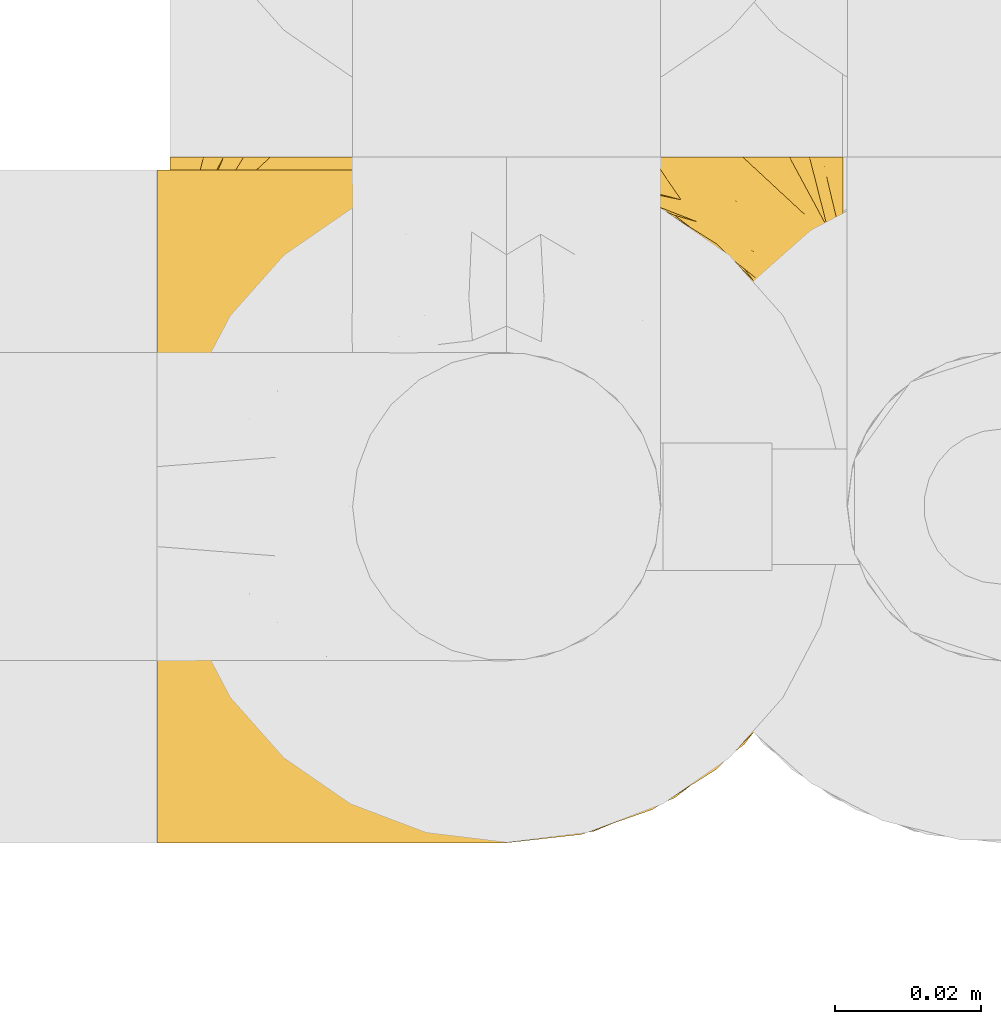
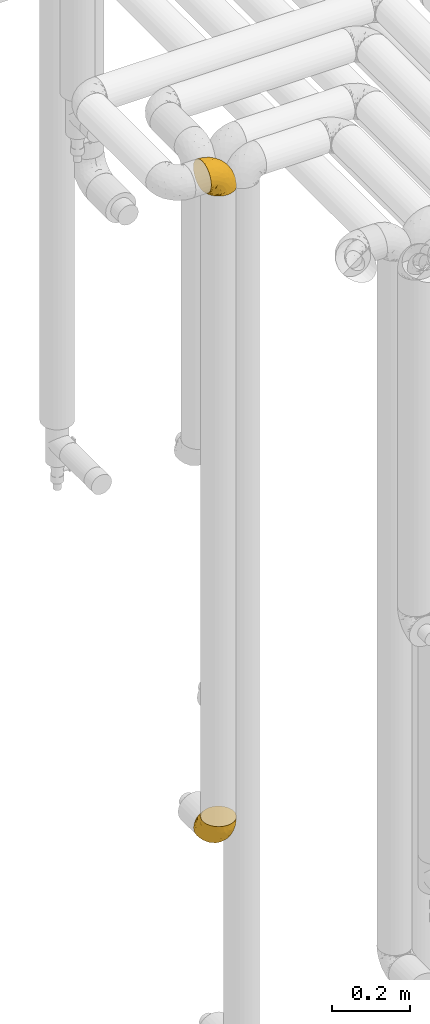
# One storey, part 250 of 827: 2 coverings.
"""IFC2X3 building model written with IfcOpenShell, lengths in millimetres."""

from ifc_helpers import new_model, entity, si_unit, converted_unit, derived_unit, direction, frame, origin, place, context, subcontext, project, spatial, faceted_brep, element, save


model = new_model("IFC2X3")

# Units and contexts
model_context = context("Model", 3, precision=0.01, world=origin(), true_north=direction((6.12303176911189e-17, 1.0)))
body_context = subcontext(model_context, "Body", "Model", "MODEL_VIEW")
ifc_project = project(units=[si_unit("LENGTHUNIT", "METRE", prefix="MILLI"), si_unit("AREAUNIT", "SQUARE_METRE"), si_unit("VOLUMEUNIT", "CUBIC_METRE"), converted_unit("PLANEANGLEUNIT", "DEGREE", entity("IfcRatioMeasure", 0.0174532925199433), si_unit("PLANEANGLEUNIT", "RADIAN"), dimensions=[0, 0, 0, 0, 0, 0, 0]), si_unit("MASSUNIT", "GRAM", prefix="KILO"), derived_unit("MASSDENSITYUNIT", [(si_unit("MASSUNIT", "GRAM", prefix="KILO"), 1), (si_unit("LENGTHUNIT", "METRE"), -3)]), derived_unit("MOMENTOFINERTIAUNIT", [(si_unit("LENGTHUNIT", "METRE"), 4)]), si_unit("TIMEUNIT", "SECOND"), si_unit("FREQUENCYUNIT", "HERTZ"), si_unit("THERMODYNAMICTEMPERATUREUNIT", "DEGREE_CELSIUS"), derived_unit("THERMALTRANSMITTANCEUNIT", [(si_unit("MASSUNIT", "GRAM", prefix="KILO"), 1), (si_unit("THERMODYNAMICTEMPERATUREUNIT", "KELVIN"), -1), (si_unit("TIMEUNIT", "SECOND"), -3)]), derived_unit("VOLUMETRICFLOWRATEUNIT", [(si_unit("LENGTHUNIT", "METRE"), 3), (si_unit("TIMEUNIT", "SECOND"), -1)]), derived_unit("MASSFLOWRATEUNIT", [(si_unit("MASSUNIT", "GRAM", prefix="KILO"), 1), (si_unit("TIMEUNIT", "SECOND"), -1)]), derived_unit("ROTATIONALFREQUENCYUNIT", [(si_unit("TIMEUNIT", "SECOND"), -1)]), si_unit("ELECTRICCURRENTUNIT", "AMPERE"), si_unit("ELECTRICVOLTAGEUNIT", "VOLT"), si_unit("POWERUNIT", "WATT"), si_unit("FORCEUNIT", "NEWTON", prefix="KILO"), si_unit("ILLUMINANCEUNIT", "LUX"), si_unit("LUMINOUSFLUXUNIT", "LUMEN"), si_unit("LUMINOUSINTENSITYUNIT", "CANDELA"), derived_unit("USERDEFINED", [(si_unit("MASSUNIT", "GRAM", prefix="KILO"), -1), (si_unit("LENGTHUNIT", "METRE"), -2), (si_unit("TIMEUNIT", "SECOND"), 3), (si_unit("LUMINOUSFLUXUNIT", "LUMEN"), 1)]), derived_unit("LINEARVELOCITYUNIT", [(si_unit("LENGTHUNIT", "METRE"), 1), (si_unit("TIMEUNIT", "SECOND"), -1)]), si_unit("PRESSUREUNIT", "PASCAL"), derived_unit("USERDEFINED", [(si_unit("LENGTHUNIT", "METRE"), -2), (si_unit("MASSUNIT", "GRAM", prefix="KILO"), 1), (si_unit("TIMEUNIT", "SECOND"), -2)]), derived_unit("LINEARFORCEUNIT", [(si_unit("MASSUNIT", "GRAM", prefix="KILO"), 1), (si_unit("LENGTHUNIT", "METRE"), 1), (si_unit("TIMEUNIT", "SECOND"), -2), (si_unit("LENGTHUNIT", "METRE"), -1)]), derived_unit("PLANARFORCEUNIT", [(si_unit("MASSUNIT", "GRAM", prefix="KILO"), 1), (si_unit("LENGTHUNIT", "METRE"), 1), (si_unit("TIMEUNIT", "SECOND"), -2), (si_unit("LENGTHUNIT", "METRE"), -2)])], contexts=[model_context])

# Site, building, storey
site_placement = place(None, origin())
site = spatial("IfcSite", under=ifc_project, at=site_placement, CompositionType="ELEMENT")
building_placement = place(site_placement, origin())
building = spatial("IfcBuilding", under=site, at=building_placement, CompositionType="ELEMENT")
storey_placement = place(building_placement, frame((0.0, 0.0, 28200.0)))
storey = spatial("IfcBuildingStorey", under=building, at=storey_placement, Name="08", CompositionType="ELEMENT", Elevation=28200.0)

# Coverings
covering_1_placement = place(storey_placement, frame((30513.93, 15693.41, 3150.4)))
element("IfcCovering", 1, at=covering_1_placement, inside=storey, Name=":ADSK_", ObjectType=":ADSK_", PredefinedType="INSULATION", context=body_context, shape_type="Brep", body=[
    faceted_brep([(78.41, 83.91, 1.6), (85.72, 76.59, 1.6), (91.22, 67.83, 1.6), (94.64, 58.07, 1.6), (95.8, 47.8, 1.6), (94.64, 37.51, 1.6), (91.22, 27.74, 1.6), (85.71, 18.98, 1.6), (78.39, 11.67, 1.6), (69.63, 6.17, 1.6), (59.87, 2.75, 1.6), (49.6, 1.6, 1.6), (45.45, 2.06, 1.6), (42.38, 2.41, 1.6), (39.31, 2.75, 1.6), (34.43, 4.46, 1.6), (29.54, 6.17, 1.6), (25.16, 8.93, 1.6), (20.78, 11.68, 1.6), (17.13, 15.34, 1.6), (13.47, 19.0, 1.6), (7.97, 27.76, 1.6), (6.26, 32.64, 1.6), (4.55, 37.52, 1.6), (3.4, 47.8, 1.6), (4.55, 58.08, 1.6), (6.26, 62.96, 1.6), (7.97, 67.85, 1.6), (13.48, 76.61, 1.6), (17.14, 80.26, 1.6), (20.8, 83.92, 1.6), (25.18, 86.67, 1.6), (29.56, 89.42, 1.6), (34.44, 91.13, 1.6), (39.32, 92.84, 1.6), (42.39, 93.18, 1.6), (45.45, 93.53, 1.6), (49.6, 94.0, 1.6), (59.88, 92.84, 1.6), (69.65, 89.42, 1.6), (1.6, 47.8, 3.4), (1.6, 35.84, 4.97), (1.6, 24.7, 9.58), (1.6, 19.91, 13.26), (1.6, 15.13, 16.93), (1.6, 11.46, 21.71), (1.6, 7.78, 26.5), (1.6, 5.48, 32.07), (1.6, 3.17, 37.64), (1.6, 2.69, 41.25), (1.6, 2.42, 43.34), (1.6, 2.14, 45.42), (1.6, 1.6, 49.6), (1.6, 3.17, 61.55), (1.6, 7.78, 72.7), (1.6, 15.13, 82.26), (1.6, 24.7, 89.61), (1.6, 35.84, 94.22), (1.6, 47.8, 95.8), (1.6, 59.75, 94.22), (1.6, 70.9, 89.61), (1.6, 80.46, 82.26), (1.6, 87.81, 72.7), (1.6, 92.42, 61.55), (1.6, 94.0, 49.6), (1.6, 93.45, 45.42), (1.6, 92.9, 41.25), (1.6, 92.42, 37.64), (1.6, 90.11, 32.07), (1.6, 87.81, 26.5), (1.6, 84.13, 21.71), (1.6, 80.46, 16.93), (1.6, 75.68, 13.26), (1.6, 70.9, 9.58), (1.6, 59.75, 4.97), (36.81, 71.98, 81.55), (23.28, 63.6, 90.4), (45.8, 59.72, 83.0), (30.7, 47.8, 91.18), (21.2, 55.16, 93.13), (12.96, 47.8, 94.0), (66.19, 63.76, 66.19), (54.51, 72.22, 70.92), (17.98, 74.18, 85.95), (36.69, 92.52, 49.74), (35.54, 94.0, 35.54), (31.64, 94.0, 38.14), (27.75, 94.0, 40.74), (23.86, 94.0, 43.34), (19.96, 94.0, 45.94), (22.8, 82.14, 77.59), (42.67, 80.34, 71.17), (33.21, 87.52, 65.81), (59.45, 79.59, 59.03), (71.5, 78.25, 45.85), (62.66, 85.01, 45.79), (54.5, 90.25, 41.42), (47.57, 93.2, 34.51), (48.81, 87.23, 56.04), (74.98, 85.55, 15.15), (18.7, 93.0, 56.51), (15.75, 89.31, 68.39), (91.17, 61.31, 23.33), (85.28, 56.86, 42.86), (82.58, 68.34, 39.42), (75.78, 65.71, 53.58), (74.98, 56.99, 59.17), (67.27, 72.15, 59.06), (87.38, 70.34, 22.63), (82.04, 78.36, 20.55), (94.0, 47.8, 12.96), (77.8, 47.8, 56.96), (67.38, 47.8, 67.38), (56.2, 93.06, 18.72), (48.85, 94.0, 5.33), (48.11, 94.0, 9.07), (47.57, 94.0, 11.79), (47.03, 94.0, 14.51), (46.48, 94.0, 17.24), (45.94, 94.0, 19.96), (65.78, 89.88, 21.03), (17.24, 94.0, 46.48), (14.51, 94.0, 47.03), (11.79, 94.0, 47.57), (9.07, 94.0, 48.11), (7.2, 94.0, 48.48), (5.33, 94.0, 48.85), (91.18, 47.8, 30.7), (43.34, 94.0, 23.86), (40.74, 94.0, 27.75), (38.14, 94.0, 31.64), (72.73, 83.7, 31.26), (56.96, 47.8, 77.8), (62.23, 55.9, 72.75), (84.49, 47.8, 43.83), (43.83, 47.8, 84.49), (12.05, 81.75, 14.58), (18.95, 86.43, 16.17), (13.02, 79.8, 10.82), (8.34, 69.84, 4.64), (14.63, 79.5, 7.71), (11.09, 88.08, 25.13), (13.66, 91.6, 32.66), (20.08, 92.93, 34.94), (9.61, 92.43, 36.76), (9.48, 93.24, 40.48), (16.1, 93.36, 39.25), (3.42, 57.25, 3.69), (26.63, 89.41, 13.99), (33.72, 92.89, 21.85), (34.77, 92.66, 17.93), (6.75, 79.58, 15.11), (13.31, 86.51, 21.14), (21.11, 86.29, 12.7), (19.94, 83.91, 7.21), (8.67, 90.94, 32.27), (26.11, 91.94, 25.68), (29.3, 91.98, 22.18), (6.32, 82.79, 18.79), (39.92, 93.16, 10.12), (27.05, 88.76, 9.47), (6.04, 73.94, 10.45), (34.4, 91.89, 11.29), (2.87, 47.8, 2.87), (20.92, 92.22, 31.16), (27.43, 88.56, 6.31), (7.54, 87.72, 25.62), (18.45, 88.33, 21.18), (23.88, 92.18, 28.81), (7.77, 71.78, 7.45), (13.3, 9.09, 21.14), (11.09, 7.51, 25.13), (6.33, 12.8, 18.79), (9.07, 1.6, 48.11), (5.33, 1.6, 48.85), (14.51, 1.6, 47.03), (11.79, 1.6, 47.57), (3.42, 38.35, 3.69), (7.76, 23.84, 7.44), (47.03, 1.6, 14.51), (47.57, 1.6, 11.79), (48.85, 1.6, 5.33), (48.11, 1.6, 9.07), (14.62, 16.1, 7.71), (27.03, 6.84, 9.47), (20.08, 2.66, 34.94), (20.92, 3.37, 31.16), (27.75, 1.6, 40.74), (31.64, 1.6, 38.14), (9.61, 3.16, 36.76), (9.48, 2.35, 40.48), (8.33, 25.77, 4.63), (6.74, 16.02, 15.11), (12.04, 13.85, 14.58), (23.86, 1.6, 43.34), (19.96, 1.6, 45.94), (16.1, 2.23, 39.25), (19.93, 11.69, 7.21), (21.1, 9.31, 12.69), (39.92, 2.43, 10.14), (33.68, 2.71, 21.81), (29.28, 3.61, 22.19), (26.62, 6.18, 14.0), (26.08, 3.66, 25.69), (18.93, 9.17, 16.17), (27.87, 6.77, 6.66), (34.75, 2.93, 17.92), (6.04, 21.66, 10.45), (38.14, 1.6, 31.64), (12.79, 16.09, 10.64), (34.41, 3.7, 11.31), (45.94, 1.6, 19.96), (43.34, 1.6, 23.86), (40.74, 1.6, 27.75), (13.66, 3.99, 32.66), (17.24, 1.6, 46.48), (8.67, 4.65, 32.27), (35.54, 1.6, 35.54), (23.83, 3.43, 28.77), (18.43, 7.27, 21.17), (6.03, 9.46, 23.36), (46.48, 1.6, 17.24), (34.52, 2.4, 47.58), (21.2, 40.43, 93.13), (23.82, 13.57, 77.44), (41.32, 11.3, 66.78), (47.62, 18.65, 71.68), (52.66, 27.26, 74.96), (36.81, 23.61, 81.55), (49.75, 3.07, 36.7), (19.07, 2.69, 56.9), (45.8, 35.87, 83.0), (23.28, 31.99, 90.4), (21.35, 6.71, 67.83), (17.98, 21.41, 85.95), (82.57, 27.24, 39.41), (91.17, 34.26, 23.33), (85.27, 38.73, 42.87), (73.89, 26.97, 53.92), (66.19, 31.83, 66.19), (62.43, 23.4, 64.12), (63.53, 6.91, 33.13), (58.45, 3.4, 23.1), (67.16, 5.84, 16.98), (62.22, 39.69, 72.75), (81.54, 17.6, 23.77), (74.8, 10.38, 18.41), (75.83, 20.6, 43.7), (41.45, 5.36, 54.53), (76.72, 35.73, 55.72), (88.2, 24.84, 17.73), (71.6, 13.87, 38.98), (56.23, 9.06, 50.28), (59.44, 15.99, 59.02)], [[[0, 1, 2, 3, 4, 5, 6, 7, 8, 9, 10, 11, 12, 13, 14, 15, 16, 17, 18, 19, 20, 21, 22, 23, 24, 25, 26, 27, 28, 29, 30, 31, 32, 33, 34, 35, 36, 37, 38, 39]], [[40, 41, 42, 43, 44, 45, 46, 47, 48, 49, 50, 51, 52, 53, 54, 55, 56, 57, 58, 59, 60, 61, 62, 63, 64, 65, 66, 67, 68, 69, 70, 71, 72, 73, 74]], [[75, 76, 77]], [[78, 79, 80]], [[77, 81, 82]], [[76, 75, 83]], [[84, 85, 86, 87, 88, 89]], [[90, 91, 92]], [[76, 60, 59]], [[93, 94, 95]], [[90, 62, 61]], [[83, 61, 60]], [[96, 97, 84]], [[98, 93, 95]], [[0, 39, 99]], [[100, 84, 89]], [[62, 101, 63]], [[2, 102, 3]], [[92, 84, 100]], [[103, 102, 104]], [[103, 105, 106]], [[93, 107, 94]], [[1, 108, 2]], [[92, 101, 90]], [[108, 1, 109]], [[102, 110, 3]], [[93, 82, 107]], [[102, 108, 104]], [[111, 106, 112]], [[109, 0, 99]], [[113, 37, 114, 115, 116, 117, 118, 119]], [[120, 38, 113]], [[100, 89, 121, 122, 123, 124, 125, 126, 64]], [[127, 102, 103]], [[97, 119, 128, 129, 130, 85]], [[99, 120, 131]], [[132, 133, 77]], [[59, 80, 79]], [[1, 0, 109]], [[98, 84, 92]], [[94, 109, 131]], [[120, 39, 38]], [[93, 91, 82]], [[104, 94, 105]], [[97, 113, 119]], [[95, 120, 96]], [[83, 90, 61]], [[91, 93, 98]], [[64, 63, 100]], [[100, 63, 101]], [[77, 76, 79]], [[133, 106, 81]], [[84, 97, 85]], [[113, 96, 120]], [[113, 97, 96]], [[37, 113, 38]], [[110, 102, 127]], [[110, 4, 3]], [[103, 111, 134, 127]], [[90, 75, 91]], [[82, 81, 107]], [[91, 75, 82]], [[77, 82, 75]], [[76, 83, 60]], [[90, 83, 75]], [[105, 107, 81]], [[94, 131, 95]], [[105, 94, 107]], [[109, 94, 104]], [[120, 95, 131]], [[98, 95, 96]], [[84, 98, 96]], [[98, 92, 91]], [[106, 105, 81]], [[103, 104, 105]], [[112, 106, 133]], [[103, 106, 111]], [[112, 133, 132]], [[81, 77, 133]], [[77, 78, 135, 132]], [[120, 99, 39]], [[109, 99, 131]], [[59, 58, 80]], [[59, 79, 76]], [[90, 101, 62]], [[100, 101, 92]], [[2, 108, 102]], [[109, 104, 108]], [[78, 77, 79]], [[136, 137, 138]], [[27, 139, 140]], [[141, 142, 143]], [[144, 145, 121]], [[146, 89, 88]], [[147, 139, 25]], [[148, 149, 150]], [[136, 151, 152]], [[147, 40, 74]], [[24, 147, 25]], [[140, 153, 154]], [[33, 116, 34]], [[73, 72, 151]], [[114, 37, 36, 35, 34, 116, 115]], [[146, 155, 144]], [[156, 85, 130]], [[157, 149, 148]], [[151, 158, 152]], [[117, 33, 159]], [[29, 154, 160]], [[161, 74, 73]], [[162, 128, 119]], [[66, 65, 64, 126, 125, 124, 123, 122, 67]], [[163, 147, 24]], [[27, 140, 28]], [[149, 129, 150]], [[139, 27, 26, 25]], [[68, 144, 69]], [[129, 128, 150]], [[164, 87, 86]], [[130, 129, 149]], [[122, 145, 67]], [[154, 153, 148]], [[162, 119, 159]], [[165, 30, 160]], [[150, 160, 148]], [[128, 162, 150]], [[30, 165, 31]], [[145, 144, 68]], [[89, 146, 144]], [[87, 164, 143]], [[166, 155, 142]], [[88, 87, 143]], [[162, 160, 150]], [[160, 30, 29]], [[154, 29, 28]], [[140, 154, 28]], [[160, 154, 148]], [[140, 137, 153]], [[157, 148, 153]], [[156, 130, 157]], [[153, 137, 157]], [[157, 137, 156]], [[167, 137, 136]], [[168, 85, 156]], [[152, 168, 167]], [[167, 168, 156]], [[164, 152, 141]], [[71, 158, 72]], [[152, 167, 136]], [[88, 142, 146]], [[144, 155, 69]], [[146, 142, 155]], [[70, 166, 71]], [[142, 141, 166]], [[70, 69, 155]], [[141, 158, 71]], [[161, 73, 151]], [[138, 137, 140]], [[161, 136, 169]], [[136, 161, 151]], [[74, 161, 169]], [[152, 158, 141]], [[151, 72, 158]], [[168, 152, 164]], [[137, 167, 156]], [[164, 86, 168]], [[85, 168, 86]], [[116, 33, 117]], [[130, 149, 157]], [[67, 145, 68]], [[121, 89, 144]], [[145, 122, 121]], [[40, 147, 163]], [[169, 147, 74]], [[159, 33, 32]], [[162, 159, 32]], [[159, 119, 118, 117]], [[139, 147, 169]], [[139, 169, 138]], [[162, 32, 31]], [[141, 143, 164]], [[88, 143, 142]], [[71, 166, 141]], [[155, 166, 70]], [[139, 138, 140]], [[169, 136, 138]], [[160, 162, 165]], [[162, 31, 165]], [[170, 171, 172]], [[173, 174, 52, 51, 50, 49, 48, 175, 176]], [[177, 178, 41]], [[179, 15, 180]], [[12, 11, 181, 182, 180, 14, 13]], [[183, 21, 20]], [[19, 18, 184]], [[185, 186, 187]], [[186, 188, 187]], [[43, 172, 44]], [[189, 190, 47]], [[23, 22, 21, 191]], [[170, 192, 193]], [[40, 163, 177]], [[194, 195, 196]], [[24, 23, 177]], [[197, 198, 183]], [[199, 15, 179]], [[47, 46, 189]], [[200, 201, 202]], [[201, 203, 204]], [[205, 206, 184]], [[207, 41, 178]], [[16, 15, 199]], [[14, 180, 15]], [[202, 201, 198]], [[208, 201, 200]], [[163, 24, 177]], [[48, 47, 190]], [[196, 195, 189]], [[197, 184, 202]], [[204, 193, 209]], [[210, 211, 212]], [[206, 212, 213]], [[205, 17, 210]], [[184, 206, 202]], [[210, 212, 206]], [[185, 194, 214]], [[189, 215, 190]], [[216, 45, 214]], [[186, 171, 170]], [[189, 216, 196]], [[197, 20, 19]], [[194, 185, 187]], [[197, 183, 20]], [[184, 197, 19]], [[197, 202, 198]], [[206, 200, 202]], [[204, 183, 198]], [[201, 208, 203]], [[203, 208, 217]], [[204, 198, 201]], [[217, 188, 218]], [[193, 219, 170]], [[171, 186, 185]], [[170, 218, 186]], [[170, 219, 218]], [[42, 207, 192]], [[171, 220, 172]], [[216, 189, 46]], [[214, 194, 196]], [[44, 220, 45]], [[214, 196, 216]], [[216, 46, 45]], [[214, 45, 220]], [[192, 43, 42]], [[204, 203, 219]], [[207, 193, 192]], [[209, 193, 178]], [[41, 207, 42]], [[193, 207, 178]], [[43, 192, 172]], [[170, 172, 192]], [[204, 219, 193]], [[219, 203, 218]], [[217, 218, 203]], [[188, 186, 218]], [[206, 213, 200]], [[208, 200, 213]], [[199, 210, 16]], [[215, 189, 195]], [[215, 175, 190]], [[175, 48, 190]], [[199, 179, 221, 211]], [[210, 199, 211]], [[23, 191, 177]], [[40, 177, 41]], [[178, 177, 191]], [[21, 183, 191]], [[209, 191, 183]], [[205, 18, 17]], [[17, 16, 210]], [[171, 185, 214]], [[172, 220, 44]], [[214, 220, 171]], [[191, 209, 178]], [[204, 209, 183]], [[206, 205, 210]], [[18, 205, 184]], [[222, 195, 194, 187, 188, 217]], [[57, 223, 80]], [[224, 225, 226]], [[226, 227, 228]], [[229, 217, 208, 213, 212, 211]], [[230, 52, 174, 173, 176, 175, 215, 195]], [[231, 232, 228]], [[231, 78, 223]], [[223, 57, 232]], [[224, 233, 225]], [[233, 54, 53]], [[234, 232, 56]], [[56, 55, 234]], [[234, 224, 228]], [[235, 236, 237]], [[224, 55, 54]], [[238, 239, 240]], [[52, 230, 53]], [[241, 242, 243]], [[227, 244, 231]], [[11, 10, 242]], [[236, 6, 5]], [[7, 245, 8]], [[8, 246, 9]], [[238, 247, 235]], [[222, 229, 248]], [[242, 211, 221, 179, 180, 182, 181, 11]], [[233, 53, 230]], [[111, 112, 249]], [[250, 6, 236]], [[246, 251, 241]], [[6, 250, 7]], [[127, 236, 110]], [[248, 229, 252]], [[246, 8, 245]], [[235, 245, 250]], [[236, 5, 110]], [[235, 249, 238]], [[237, 236, 127]], [[243, 9, 246]], [[252, 229, 241]], [[56, 232, 57]], [[222, 230, 195]], [[225, 248, 252]], [[248, 233, 230]], [[54, 233, 224]], [[231, 228, 227]], [[244, 132, 231]], [[248, 225, 233]], [[226, 225, 253]], [[235, 250, 236]], [[245, 7, 250]], [[251, 246, 245]], [[243, 246, 241]], [[247, 245, 235]], [[252, 251, 253]], [[229, 222, 217]], [[230, 222, 248]], [[5, 4, 110]], [[237, 127, 134, 111]], [[238, 249, 239]], [[224, 234, 55]], [[232, 234, 228]], [[242, 241, 229]], [[10, 9, 243]], [[211, 242, 229]], [[10, 243, 242]], [[80, 223, 78]], [[80, 58, 57]], [[231, 223, 232]], [[227, 240, 239]], [[224, 226, 228]], [[240, 226, 253]], [[227, 239, 244]], [[226, 240, 227]], [[251, 247, 253]], [[240, 253, 247]], [[249, 235, 237]], [[237, 111, 249]], [[112, 132, 244]], [[112, 244, 249]], [[78, 231, 132, 135]], [[249, 244, 239]], [[247, 238, 240]], [[245, 247, 251]], [[251, 252, 241]], [[225, 252, 253]]]),
])
covering_2_placement = place(storey_placement, frame((30515.73, 15693.41, 1082.65)))
element("IfcCovering", 2, at=covering_2_placement, inside=storey, Name=":ADSK_", ObjectType=":ADSK_", PredefinedType="INSULATION", context=body_context, shape_type="Brep", body=[
    faceted_brep([(83.91, 95.8, 18.98), (76.59, 95.8, 11.67), (67.83, 95.8, 6.17), (58.07, 95.8, 2.75), (47.8, 95.8, 1.6), (37.51, 95.8, 2.75), (27.74, 95.8, 6.17), (18.98, 95.8, 11.68), (11.67, 95.8, 19.0), (6.17, 95.8, 27.76), (2.75, 95.8, 37.52), (1.6, 95.8, 47.8), (2.06, 95.8, 51.94), (2.41, 95.8, 55.01), (2.75, 95.8, 58.08), (4.46, 95.8, 62.96), (6.17, 95.8, 67.85), (8.93, 95.8, 72.23), (11.68, 95.8, 76.61), (15.34, 95.8, 80.26), (19.0, 95.8, 83.92), (27.76, 95.8, 89.42), (32.64, 95.8, 91.13), (37.52, 95.8, 92.84), (47.8, 95.8, 94.0), (58.08, 95.8, 92.84), (62.96, 95.8, 91.13), (67.85, 95.8, 89.42), (76.61, 95.8, 83.91), (80.26, 95.8, 80.25), (83.92, 95.8, 76.59), (86.67, 95.8, 72.21), (89.42, 95.8, 67.83), (91.13, 95.8, 62.95), (92.84, 95.8, 58.07), (93.18, 95.8, 55.0), (93.53, 95.8, 51.94), (94.0, 95.8, 47.8), (92.84, 95.8, 37.51), (89.42, 95.8, 27.74), (47.8, 94.0, 95.8), (35.84, 92.42, 95.8), (24.7, 87.81, 95.8), (19.91, 84.13, 95.8), (15.13, 80.46, 95.8), (11.46, 75.68, 95.8), (7.78, 70.9, 95.8), (5.48, 65.32, 95.8), (3.17, 59.75, 95.8), (2.69, 56.14, 95.8), (2.42, 54.06, 95.8), (2.14, 51.97, 95.8), (1.6, 47.8, 95.8), (3.17, 35.84, 95.8), (7.78, 24.7, 95.8), (15.13, 15.13, 95.8), (24.7, 7.78, 95.8), (35.84, 3.17, 95.8), (47.8, 1.6, 95.8), (59.75, 3.17, 95.8), (70.9, 7.78, 95.8), (80.46, 15.13, 95.8), (87.81, 24.7, 95.8), (92.42, 35.84, 95.8), (94.0, 47.8, 95.8), (93.45, 51.97, 95.8), (92.9, 56.14, 95.8), (92.42, 59.75, 95.8), (90.11, 65.32, 95.8), (87.81, 70.9, 95.8), (84.13, 75.68, 95.8), (80.46, 80.46, 95.8), (75.68, 84.13, 95.8), (70.9, 87.81, 95.8), (59.75, 92.42, 95.8), (71.98, 15.84, 60.58), (63.6, 6.99, 74.11), (59.72, 14.39, 51.59), (47.8, 6.21, 66.69), (55.16, 4.26, 76.19), (47.8, 3.39, 84.43), (63.76, 31.2, 31.2), (72.22, 26.47, 42.88), (74.18, 11.44, 79.41), (92.52, 47.66, 60.7), (94.0, 61.85, 61.85), (94.0, 59.25, 65.75), (94.0, 56.65, 69.64), (94.0, 54.05, 73.53), (94.0, 51.45, 77.43), (82.14, 19.8, 74.59), (80.34, 26.22, 54.72), (87.52, 31.58, 64.18), (79.59, 38.36, 37.94), (78.25, 51.54, 25.89), (85.01, 51.6, 34.73), (90.25, 55.97, 42.89), (93.2, 62.88, 49.83), (87.23, 41.35, 48.58), (85.55, 82.24, 22.41), (93.0, 40.88, 78.69), (89.31, 29.0, 81.64), (61.31, 74.06, 6.22), (56.86, 54.53, 12.11), (68.34, 57.98, 14.81), (65.71, 43.81, 21.61), (56.99, 38.22, 22.41), (72.15, 38.33, 30.12), (70.34, 74.76, 10.01), (78.36, 76.85, 15.36), (47.8, 84.43, 3.39), (47.8, 40.43, 19.59), (47.8, 30.01, 30.01), (93.06, 78.67, 41.19), (94.0, 92.06, 48.54), (94.0, 88.32, 49.28), (94.0, 85.6, 49.82), (94.0, 82.88, 50.37), (94.0, 80.15, 50.91), (94.0, 77.43, 51.45), (89.88, 76.36, 31.61), (94.0, 50.91, 80.15), (94.0, 50.37, 82.88), (94.0, 49.82, 85.6), (94.0, 49.28, 88.32), (94.0, 48.91, 90.19), (94.0, 48.54, 92.06), (47.8, 66.69, 6.21), (94.0, 73.53, 54.05), (94.0, 69.64, 56.65), (94.0, 65.75, 59.25), (83.7, 66.13, 24.66), (47.8, 19.59, 40.43), (55.9, 24.64, 35.17), (47.8, 53.56, 12.9), (47.8, 12.9, 53.56), (81.75, 82.81, 85.34), (86.43, 81.22, 78.44), (79.8, 86.57, 84.37), (69.84, 92.75, 89.05), (79.5, 89.68, 82.76), (88.08, 72.26, 86.31), (91.6, 64.73, 83.73), (92.93, 62.45, 77.31), (92.43, 60.63, 87.78), (93.24, 56.91, 87.91), (93.36, 58.14, 81.29), (57.25, 93.7, 93.97), (89.41, 83.4, 70.76), (92.89, 75.54, 63.67), (92.66, 79.46, 62.62), (79.58, 82.28, 90.64), (86.51, 76.25, 84.08), (83.91, 90.18, 77.45), (88.76, 87.92, 70.34), (90.94, 65.12, 88.72), (91.94, 71.71, 71.28), (91.98, 75.21, 68.09), (82.79, 78.6, 91.07), (93.16, 87.27, 57.47), (73.94, 86.94, 91.35), (91.89, 86.1, 62.99), (47.8, 94.52, 94.52), (92.22, 66.23, 76.47), (86.29, 84.69, 76.28), (88.56, 91.08, 69.96), (87.72, 71.77, 89.86), (88.33, 76.21, 78.94), (92.18, 68.59, 73.51), (71.78, 89.94, 89.62), (9.09, 76.25, 84.09), (7.51, 72.26, 86.3), (12.8, 78.6, 91.06), (1.6, 48.54, 92.06), (1.6, 50.37, 82.88), (1.6, 49.82, 85.6), (1.6, 49.28, 88.32), (38.35, 93.7, 93.97), (23.84, 89.95, 89.63), (1.6, 82.88, 50.37), (1.6, 85.6, 49.82), (1.6, 92.06, 48.54), (1.6, 88.32, 49.28), (16.1, 89.68, 82.77), (6.84, 87.92, 70.36), (2.66, 62.45, 77.31), (3.37, 66.24, 76.47), (1.6, 56.65, 69.64), (1.6, 59.25, 65.75), (3.16, 60.63, 87.78), (2.35, 56.91, 87.91), (25.77, 92.76, 89.06), (16.02, 82.28, 90.65), (13.85, 82.81, 85.35), (1.6, 54.05, 73.53), (1.6, 51.45, 77.43), (2.23, 58.14, 81.29), (11.69, 90.18, 77.46), (9.31, 84.7, 76.29), (2.43, 87.25, 57.47), (2.71, 75.58, 63.71), (3.61, 75.2, 68.11), (6.18, 83.39, 70.77), (3.66, 71.7, 71.31), (9.17, 81.22, 78.46), (6.77, 90.73, 69.52), (2.93, 79.47, 62.64), (21.66, 86.94, 91.35), (1.6, 65.75, 59.25), (16.09, 86.75, 84.6), (3.7, 86.08, 62.98), (1.6, 77.43, 51.45), (1.6, 73.53, 54.05), (1.6, 69.64, 56.65), (3.99, 64.73, 83.73), (1.6, 50.91, 80.15), (4.65, 65.12, 88.72), (1.6, 61.85, 61.85), (3.43, 68.62, 73.56), (7.27, 76.22, 78.96), (9.46, 74.03, 91.36), (1.6, 80.15, 50.91), (2.4, 49.81, 62.87), (40.43, 4.26, 76.19), (13.57, 19.95, 73.57), (11.3, 30.61, 56.07), (18.65, 25.71, 49.77), (27.26, 22.43, 44.73), (23.61, 15.85, 60.58), (3.07, 60.69, 47.64), (2.69, 40.49, 78.32), (35.87, 14.39, 51.59), (31.99, 6.99, 74.11), (6.71, 29.56, 76.04), (21.41, 11.45, 79.41), (27.24, 57.98, 14.82), (34.26, 74.06, 6.22), (38.73, 54.52, 12.12), (26.97, 43.47, 23.51), (31.83, 31.2, 31.2), (23.4, 33.27, 34.96), (6.91, 64.26, 33.86), (3.4, 74.29, 38.94), (5.84, 80.41, 30.23), (35.73, 41.67, 20.67), (39.69, 24.64, 35.17), (17.6, 73.62, 15.85), (10.38, 78.98, 22.59), (20.6, 53.69, 21.56), (5.36, 42.86, 55.94), (24.84, 79.66, 9.19), (13.87, 58.41, 25.79), (9.06, 47.11, 41.16), (15.99, 38.37, 37.95)], [[[0, 1, 2, 3, 4, 5, 6, 7, 8, 9, 10, 11, 12, 13, 14, 15, 16, 17, 18, 19, 20, 21, 22, 23, 24, 25, 26, 27, 28, 29, 30, 31, 32, 33, 34, 35, 36, 37, 38, 39]], [[40, 41, 42, 43, 44, 45, 46, 47, 48, 49, 50, 51, 52, 53, 54, 55, 56, 57, 58, 59, 60, 61, 62, 63, 64, 65, 66, 67, 68, 69, 70, 71, 72, 73, 74]], [[75, 76, 77]], [[78, 79, 80]], [[77, 81, 82]], [[76, 75, 83]], [[84, 85, 86, 87, 88, 89]], [[90, 91, 92]], [[76, 60, 59]], [[93, 94, 95]], [[90, 62, 61]], [[83, 61, 60]], [[96, 97, 84]], [[98, 93, 95]], [[0, 39, 99]], [[100, 84, 89]], [[62, 101, 63]], [[2, 102, 3]], [[92, 84, 100]], [[103, 102, 104]], [[103, 105, 106]], [[93, 107, 94]], [[1, 108, 2]], [[92, 101, 90]], [[108, 1, 109]], [[102, 110, 3]], [[93, 82, 107]], [[102, 108, 104]], [[111, 106, 112]], [[109, 0, 99]], [[113, 37, 114, 115, 116, 117, 118, 119]], [[120, 38, 113]], [[100, 89, 121, 122, 123, 124, 125, 126, 64]], [[127, 102, 103]], [[97, 119, 128, 129, 130, 85]], [[99, 120, 131]], [[132, 133, 77]], [[59, 80, 79]], [[1, 0, 109]], [[98, 84, 92]], [[94, 109, 131]], [[120, 39, 38]], [[93, 91, 82]], [[104, 94, 105]], [[97, 113, 119]], [[95, 120, 96]], [[83, 90, 61]], [[91, 93, 98]], [[64, 63, 100]], [[100, 63, 101]], [[77, 76, 79]], [[133, 106, 81]], [[84, 97, 85]], [[113, 96, 120]], [[113, 97, 96]], [[37, 113, 38]], [[110, 102, 127]], [[110, 4, 3]], [[103, 111, 134, 127]], [[90, 75, 91]], [[82, 81, 107]], [[91, 75, 82]], [[77, 82, 75]], [[76, 83, 60]], [[90, 83, 75]], [[105, 107, 81]], [[94, 131, 95]], [[105, 94, 107]], [[109, 94, 104]], [[120, 95, 131]], [[98, 95, 96]], [[84, 98, 96]], [[98, 92, 91]], [[106, 105, 81]], [[103, 104, 105]], [[133, 132, 112]], [[103, 106, 111]], [[77, 78, 135, 132]], [[81, 77, 133]], [[106, 133, 112]], [[120, 99, 39]], [[109, 99, 131]], [[59, 58, 80]], [[59, 79, 76]], [[90, 101, 62]], [[100, 101, 92]], [[2, 108, 102]], [[109, 104, 108]], [[78, 77, 79]], [[136, 137, 138]], [[27, 139, 140]], [[141, 142, 143]], [[144, 145, 121]], [[146, 89, 88]], [[147, 139, 25]], [[148, 149, 150]], [[136, 151, 152]], [[147, 40, 74]], [[24, 147, 25]], [[153, 148, 154]], [[33, 116, 34]], [[73, 72, 151]], [[114, 37, 36, 35, 34, 116, 115]], [[146, 155, 144]], [[156, 85, 130]], [[157, 149, 148]], [[151, 158, 152]], [[117, 33, 159]], [[29, 153, 154]], [[160, 74, 73]], [[161, 128, 119]], [[66, 65, 64, 126, 125, 124, 123, 122, 67]], [[162, 147, 24]], [[27, 140, 28]], [[149, 129, 150]], [[139, 27, 26, 25]], [[68, 144, 69]], [[129, 128, 150]], [[163, 87, 86]], [[130, 129, 149]], [[122, 145, 67]], [[153, 164, 148]], [[161, 119, 159]], [[165, 30, 154]], [[150, 154, 148]], [[128, 161, 150]], [[30, 165, 31]], [[145, 144, 68]], [[89, 146, 144]], [[87, 163, 143]], [[166, 155, 142]], [[88, 87, 143]], [[161, 154, 150]], [[154, 30, 29]], [[29, 28, 153]], [[28, 140, 153]], [[164, 153, 140]], [[140, 137, 164]], [[157, 148, 164]], [[156, 130, 157]], [[164, 137, 157]], [[157, 137, 156]], [[167, 137, 136]], [[168, 85, 156]], [[152, 168, 167]], [[167, 168, 156]], [[163, 152, 141]], [[71, 158, 72]], [[152, 167, 136]], [[88, 142, 146]], [[144, 155, 69]], [[146, 142, 155]], [[70, 166, 71]], [[142, 141, 166]], [[70, 69, 155]], [[141, 158, 71]], [[160, 73, 151]], [[138, 137, 140]], [[160, 136, 169]], [[136, 160, 151]], [[74, 160, 169]], [[152, 158, 141]], [[151, 72, 158]], [[168, 152, 163]], [[137, 167, 156]], [[163, 86, 168]], [[85, 168, 86]], [[116, 33, 117]], [[130, 149, 157]], [[67, 145, 68]], [[121, 89, 144]], [[145, 122, 121]], [[40, 147, 162]], [[169, 147, 74]], [[159, 33, 32]], [[161, 159, 32]], [[159, 119, 118, 117]], [[139, 147, 169]], [[139, 169, 138]], [[161, 32, 31]], [[141, 143, 163]], [[88, 143, 142]], [[71, 166, 141]], [[155, 166, 70]], [[139, 138, 140]], [[169, 136, 138]], [[154, 161, 165]], [[161, 31, 165]], [[170, 171, 172]], [[173, 52, 51, 50, 49, 48, 174, 175, 176]], [[177, 178, 41]], [[179, 15, 180]], [[12, 11, 181, 182, 180, 14, 13]], [[183, 21, 20]], [[19, 18, 184]], [[185, 186, 187]], [[186, 188, 187]], [[43, 172, 44]], [[189, 190, 47]], [[23, 22, 21, 191]], [[170, 192, 193]], [[40, 162, 177]], [[194, 195, 196]], [[24, 23, 177]], [[197, 198, 183]], [[199, 15, 179]], [[47, 46, 189]], [[200, 201, 202]], [[201, 203, 204]], [[205, 206, 184]], [[207, 41, 178]], [[16, 15, 199]], [[14, 180, 15]], [[202, 201, 198]], [[208, 201, 200]], [[162, 24, 177]], [[48, 47, 190]], [[196, 195, 189]], [[197, 184, 202]], [[204, 193, 209]], [[210, 211, 212]], [[206, 212, 213]], [[205, 17, 210]], [[184, 206, 202]], [[210, 212, 206]], [[185, 194, 214]], [[189, 215, 190]], [[216, 45, 214]], [[186, 171, 170]], [[189, 216, 196]], [[197, 20, 19]], [[194, 185, 187]], [[197, 183, 20]], [[184, 197, 19]], [[197, 202, 198]], [[206, 200, 202]], [[204, 183, 198]], [[201, 208, 203]], [[203, 208, 217]], [[204, 198, 201]], [[217, 188, 218]], [[193, 219, 170]], [[171, 186, 185]], [[170, 218, 186]], [[170, 219, 218]], [[42, 207, 192]], [[171, 220, 172]], [[216, 189, 46]], [[214, 194, 196]], [[44, 220, 45]], [[214, 196, 216]], [[216, 46, 45]], [[214, 45, 220]], [[192, 43, 42]], [[204, 203, 219]], [[207, 193, 192]], [[209, 193, 178]], [[41, 207, 42]], [[193, 207, 178]], [[43, 192, 172]], [[170, 172, 192]], [[204, 219, 193]], [[219, 203, 218]], [[217, 218, 203]], [[188, 186, 218]], [[206, 213, 200]], [[208, 200, 213]], [[199, 210, 16]], [[215, 189, 195]], [[215, 174, 190]], [[174, 48, 190]], [[199, 179, 221, 211]], [[210, 199, 211]], [[23, 191, 177]], [[40, 177, 41]], [[183, 209, 191]], [[183, 191, 21]], [[191, 178, 177]], [[205, 18, 17]], [[17, 16, 210]], [[171, 185, 214]], [[172, 220, 44]], [[214, 220, 171]], [[191, 209, 178]], [[204, 209, 183]], [[206, 205, 210]], [[18, 205, 184]], [[222, 195, 194, 187, 188, 217]], [[57, 223, 80]], [[224, 225, 226]], [[226, 227, 228]], [[229, 217, 208, 213, 212, 211]], [[230, 52, 173, 176, 175, 174, 215, 195]], [[231, 232, 228]], [[231, 78, 223]], [[223, 57, 232]], [[224, 233, 225]], [[233, 54, 53]], [[234, 232, 56]], [[56, 55, 234]], [[234, 224, 228]], [[235, 236, 237]], [[224, 55, 54]], [[238, 239, 240]], [[52, 230, 53]], [[241, 242, 243]], [[239, 244, 245]], [[11, 10, 242]], [[236, 6, 5]], [[7, 246, 8]], [[8, 247, 9]], [[238, 248, 235]], [[222, 229, 249]], [[242, 211, 221, 179, 180, 182, 181, 11]], [[233, 53, 230]], [[111, 112, 244]], [[250, 6, 236]], [[247, 251, 241]], [[6, 250, 7]], [[127, 236, 110]], [[249, 229, 252]], [[247, 8, 246]], [[235, 246, 250]], [[236, 5, 110]], [[235, 244, 238]], [[237, 236, 127]], [[243, 9, 247]], [[252, 229, 241]], [[56, 232, 57]], [[222, 230, 195]], [[225, 249, 252]], [[249, 233, 230]], [[54, 233, 224]], [[231, 228, 227]], [[245, 132, 231]], [[249, 225, 233]], [[226, 225, 253]], [[235, 250, 236]], [[246, 7, 250]], [[251, 247, 246]], [[243, 247, 241]], [[248, 246, 235]], [[252, 251, 253]], [[229, 222, 217]], [[230, 222, 249]], [[5, 4, 110]], [[237, 127, 134, 111]], [[238, 244, 239]], [[224, 234, 55]], [[232, 234, 228]], [[242, 241, 229]], [[10, 9, 243]], [[211, 242, 229]], [[10, 243, 242]], [[80, 223, 78]], [[80, 58, 57]], [[231, 223, 232]], [[227, 240, 239]], [[224, 226, 228]], [[240, 226, 253]], [[227, 239, 245]], [[226, 240, 227]], [[251, 248, 253]], [[240, 253, 248]], [[244, 235, 237]], [[237, 111, 244]], [[132, 245, 112]], [[112, 245, 244]], [[135, 78, 231, 132]], [[227, 245, 231]], [[248, 238, 240]], [[246, 248, 251]], [[251, 252, 241]], [[225, 252, 253]]]),
])

save(model, "model.ifc")
